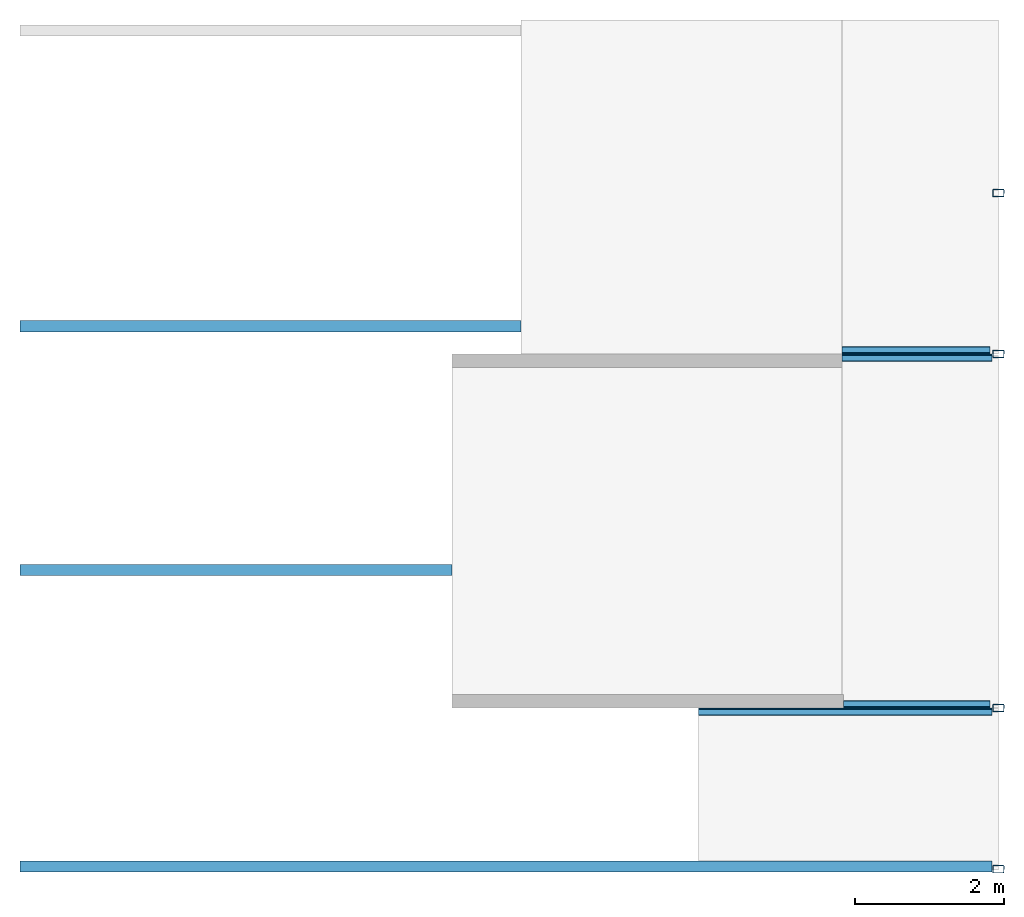
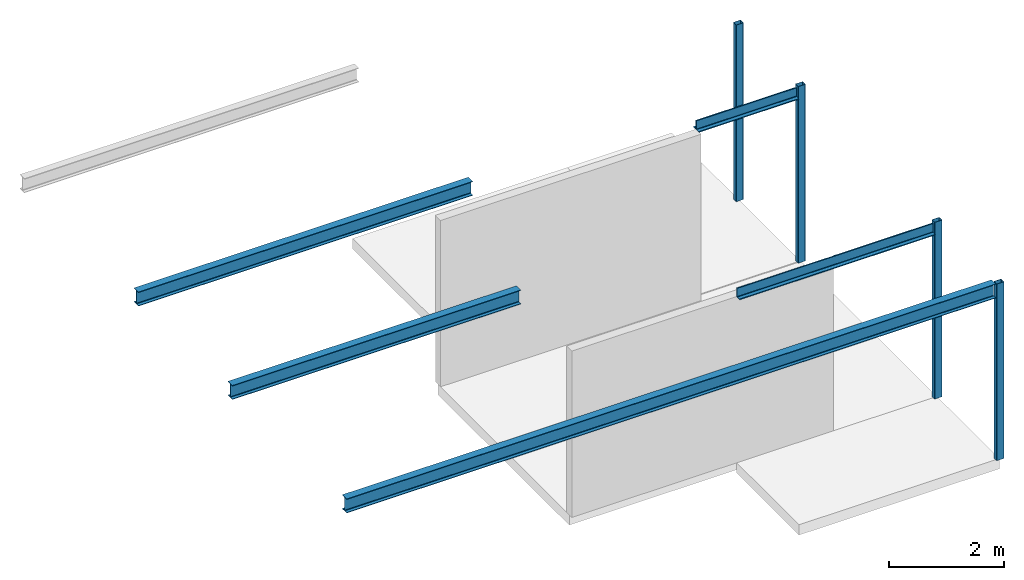
# One storey, part 1 of 2: 7 beams, 4 columns.
"""IFC2X3 building model written with IfcOpenShell, lengths in millimetres."""

from ifc_helpers import new_model, entity, si_unit, converted_unit, frame, frame_2d, origin, place, context, project, spatial, polyline, circle_curve, parameter, trimmed, segment, composite_curve, outline, extrude, source, transform, mapped, material, type_object, type_shapes, element, save


model = new_model("IFC2X3")

# Units and contexts
model_context = context("Model", 3, precision=1e-06, world=origin())
plan_context = context("Plan", 3, precision=1e-06, world=origin())
ifc_project = project(units=[si_unit("LENGTHUNIT", "METRE", prefix="MILLI"), si_unit("AREAUNIT", "SQUARE_METRE", prefix="MILLI"), si_unit("VOLUMEUNIT", "CUBIC_METRE", prefix="MILLI"), converted_unit("PLANEANGLEUNIT", "DEGREE", entity("IfcRatioMeasure", 0.01745329251994328), si_unit("PLANEANGLEUNIT", "RADIAN"), dimensions=[0, 0, 0, 0, 0, 0, 0]), si_unit("TIMEUNIT", "SECOND")], contexts=[model_context, plan_context])

# Site, building, storey
site_placement = place(None, origin())
site = spatial("IfcSite", under=ifc_project, at=site_placement, CompositionType="ELEMENT")
building_placement = place(None, origin())
building = spatial("IfcBuilding", under=site, at=building_placement, CompositionType="ELEMENT")
storey_placement = place(building_placement, frame((0.0, 0.0, 7500.0)))
storey = spatial("IfcBuildingStorey", under=building, at=storey_placement, Name="Level 3", CompositionType="ELEMENT", Elevation=7500.000000000001)

# Columns
ifc_material = material(Name="Metal - Steel - 345 MPa")
column_type = type_object("IfcColumnType", Name="150x100x5", PredefinedType="COLUMN")
shared_shape = source(origin(), model_context, "Body", "SweptSolid", [
    extrude(outline(composite_curve([segment(polyline([(-40.0, -75.0), (40.0, -75.0)]), True, "CONTINUOUS"), segment(trimmed(circle_curve(frame_2d((40.0, -65.0), x_axis=(-1.0, 0.0)), 9.999999999997998), [parameter(90.00000000000009)], [parameter(180.0000000000002)], True, "PARAMETER"), True, "CONTINUOUS"), segment(polyline([(50.0, -65.0), (50.0, 65.0)]), True, "CONTINUOUS"), segment(trimmed(circle_curve(frame_2d((40.0, 65.0), x_axis=(-1.0, 0.0)), 9.99999999999999), [parameter(179.9999999999999)], [parameter(269.9999999999997)], True, "PARAMETER"), True, "CONTINUOUS"), segment(polyline([(40.0, 75.0), (-40.0, 75.0)]), True, "CONTINUOUS"), segment(trimmed(circle_curve(frame_2d((-40.0, 65.0), x_axis=(-1.0, 0.0)), 10.00000000000288), [parameter(269.9999999999995)], [parameter(359.9999999999996)], True, "PARAMETER"), True, "CONTINUOUS"), segment(polyline([(-50.0, 65.0), (-50.0, -65.0)]), True, "CONTINUOUS"), segment(trimmed(circle_curve(frame_2d((-40.0, -65.0), x_axis=(-1.0, 0.0)), 9.999999999996726), [parameter(359.9999999999996)], [parameter(89.99999999999963)], True, "PARAMETER"), True, "CONTINUOUS")], self_intersect=False), holes=[composite_curve([segment(trimmed(circle_curve(frame_2d((-40.0, -65.0), x_axis=(-1.0, 0.0)), 4.999999999996471), [parameter(0.0)], [parameter(89.99999999999999)], True, "PARAMETER"), False, "CONTINUOUS"), segment(polyline([(-45.0, -65.0), (-45.0, 65.0)]), True, "CONTINUOUS"), segment(trimmed(circle_curve(frame_2d((-40.0, 65.0), x_axis=(-1.0, 0.0)), 4.999999999998176), [parameter(270.0)], [parameter(359.9999999999999)], True, "PARAMETER"), False, "CONTINUOUS"), segment(polyline([(-40.0, 70.0), (40.0, 70.0)]), True, "CONTINUOUS"), segment(trimmed(circle_curve(frame_2d((40.0, 65.0), x_axis=(-1.0, 0.0)), 5.000000000001551), [parameter(180.0000000000001)], [parameter(270.0)], True, "PARAMETER"), False, "CONTINUOUS"), segment(polyline([(45.0, 65.0), (45.0, -65.0)]), True, "CONTINUOUS"), segment(trimmed(circle_curve(frame_2d((40.0, -65.0), x_axis=(-1.0, 0.0)), 5.000000000000011), [parameter(90.0000000000005)], [parameter(179.9999999999998)], True, "PARAMETER"), False, "CONTINUOUS"), segment(polyline([(40.0, -70.0), (-40.0, -70.0)]), True, "CONTINUOUS")], self_intersect=False)]), frame((0.0, 0.0, 7500.0), z_axis=(0.0, 0.0, 1.0), x_axis=(-1.0, 0.0, 0.0)), (0.0, 0.0, 1.0), 3750.0),
])
type_shapes(column_type, [shared_shape])
for number, where, z_axis, x_axis in (
    (1, (-11917.18323242557, 151.098768151623, -7500.0), (0.0, 0.0, 1.0), (0.0, 1.0, 0.0)),
    (2, (-11917.18323242557, 2311.098768151621, -7500.0), (0.0, 0.0, 1.0), (0.0, 1.0, 0.0)),
    (3, (-11917.18323242557, 7061.098768151644, -7500.0), (0.0, 0.0, 1.0), (0.0, 1.0, 0.0)),
    (4, (-11917.18323242557, 9217.072263559809, -7500.0), (0.0, 0.0, 1.0), (0.0, 1.0, 0.0)),
):
    element("IfcColumn", number, at=place(storey_placement, frame(where, z_axis=z_axis, x_axis=x_axis)), inside=storey, type_object=column_type, material=ifc_material, ObjectType="150x100x5", context=model_context, shape_type="MappedRepresentation", body=[
        mapped(shared_shape, transform((0.0, 0.0, 0.0), scale=1.0)),
    ])

# Beams
beam_1_placement = place(storey_placement, frame((-12017.18323242538, 7061.098768151644, 3750.0), z_axis=(0.0, 0.0, 1.0), x_axis=(0.0, 1.0, 0.0)))
element("IfcBeam", 5, at=beam_1_placement, inside=storey, material=ifc_material, ObjectType="L-Angles:CAI200x100x14", context=model_context, shape_type="SweptSolid", body=[
    extrude(outline(composite_curve([segment(polyline([(-34.57142857142937, -63.1428571428558), (65.42857142857281, -63.1428571428558)]), True, "CONTINUOUS"), segment(trimmed(circle_curve(frame_2d((51.42857142857381, -63.1428571428558), x_axis=(1.0, 0.0)), 14.0), [parameter(1.017777498068326e-13)], [parameter(90.00000000000009)], True, "PARAMETER"), True, "CONTINUOUS"), segment(polyline([(51.42857142857381, -49.1428571428568), (-6.571428571429244, -49.1428571428568)]), True, "CONTINUOUS"), segment(trimmed(circle_curve(frame_2d((-6.571428571428161, -35.14285714285566), x_axis=(1.0, 0.0)), 14.0), [parameter(180.0000000000001)], [parameter(269.9999999999999)], True, "PARAMETER"), False, "CONTINUOUS"), segment(polyline([(-20.57142857142823, -35.14285714285566), (-20.57142857142823, 122.8571428571452)]), True, "CONTINUOUS"), segment(trimmed(circle_curve(frame_2d((-34.57142857142829, 122.8571428571431), x_axis=(1.0, 0.0)), 14.0), [parameter(0.0)], [parameter(90.00000000000024)], True, "PARAMETER"), True, "CONTINUOUS"), segment(polyline([(-34.57142857142829, 136.8571428571442), (-34.57142857142937, -63.1428571428558)]), True, "CONTINUOUS")], self_intersect=False)), frame((34.57142857142829, 1994.442034597584, -170.8571428571387), z_axis=(0.0, -1.0, 0.0), x_axis=(1.0, 0.0, 0.0)), (0.0, 0.0, 1.0), 1981.742033987986),
])
beam_2_placement = place(storey_placement, frame((-14011.62526702297, 7061.098768151647, 3750.0), z_axis=(0.0, 0.0, 1.0), x_axis=(0.0, -1.0, 0.0)))
element("IfcBeam", 6, at=beam_2_placement, inside=storey, material=ifc_material, ObjectType="L-Angles:CAI200x100x14", context=model_context, shape_type="SweptSolid", body=[
    extrude(outline(composite_curve([segment(polyline([(-63.14285714285599, -34.57142857142903), (136.857142857144, -34.57142857142903)]), True, "CONTINUOUS"), segment(trimmed(circle_curve(frame_2d((122.8571428571429, -34.57142857142896), x_axis=(0.0, 1.0)), 14.0), [parameter(269.9999999999998)], [parameter(0.0)], True, "PARAMETER"), True, "CONTINUOUS"), segment(polyline([(122.8571428571451, -20.57142857142889), (-35.14285714285578, -20.57142857142804)]), True, "CONTINUOUS"), segment(trimmed(circle_curve(frame_2d((-35.1428571428557, -6.571428571427971), x_axis=(0.0, 1.0)), 14.0), [parameter(90.00000000000009)], [parameter(179.9999999999999)], True, "PARAMETER"), False, "CONTINUOUS"), segment(polyline([(-49.14285714285683, -6.571428571428978), (-49.14285714285652, 51.42857142857407)]), True, "CONTINUOUS"), segment(trimmed(circle_curve(frame_2d((-63.14285714285553, 51.42857142857415), x_axis=(0.0, 1.0)), 14.0), [parameter(269.9999999999999)], [parameter(359.9999999999999)], True, "PARAMETER"), True, "CONTINUOUS"), segment(polyline([(-63.14285714285545, 65.42857142857315), (-63.14285714285599, -34.57142857142903)]), True, "CONTINUOUS")], self_intersect=False)), frame((34.57142857142829, 0.0, -170.8571428571387), z_axis=(0.0, 1.0, 0.0), x_axis=(0.0, 0.0, 1.0)), (0.0, 0.0, 1.0), 2006.742034597402),
])
beam_3_placement = place(storey_placement, frame((-12017.18323242539, 2311.098768151621, 3750.0), z_axis=(0.0, 0.0, 1.0), x_axis=(0.0, 1.0, 0.0)))
element("IfcBeam", 7, at=beam_3_placement, inside=storey, material=ifc_material, ObjectType="L-Angles:CAI200x100x14", context=model_context, shape_type="SweptSolid", body=[
    extrude(outline(composite_curve([segment(polyline([(-34.5714285714291, -63.1428571428558), (65.42857142857306, -63.1428571428558)]), True, "CONTINUOUS"), segment(trimmed(circle_curve(frame_2d((51.428571428573, -63.1428571428558), x_axis=(0.0, 1.0)), 14.0), [parameter(269.9999999999999)], [parameter(359.9999999999999)], True, "PARAMETER"), True, "CONTINUOUS"), segment(polyline([(51.428571428573, -49.1428571428568), (-6.571428571428971, -49.1428571428568)]), True, "CONTINUOUS"), segment(trimmed(circle_curve(frame_2d((-6.571428571428971, -35.14285714285566), x_axis=(-1.0, 0.0)), 14.0), [parameter(3.562221243239142e-13)], [parameter(90.00000000000009)], True, "PARAMETER"), False, "CONTINUOUS"), segment(polyline([(-20.57142857142904, -35.14285714285566), (-20.5714285714285, 122.8571428571452)]), True, "CONTINUOUS"), segment(trimmed(circle_curve(frame_2d((-34.57142857142856, 122.8571428571431), x_axis=(0.0, 1.0)), 14.0), [parameter(269.9999999999999)], [parameter(1.52666624710249e-13)], True, "PARAMETER"), True, "CONTINUOUS"), segment(polyline([(-34.57142857142856, 136.8571428571442), (-34.5714285714291, -63.1428571428558)]), True, "CONTINUOUS")], self_intersect=False)), frame((34.57142857142883, 1980.0, -170.8571428571387), z_axis=(0.0, -1.0, 0.0), x_axis=(1.0, 0.0, 0.0)), (0.0, 0.0, 1.0), 1967.299999390401),
])
beam_4_placement = place(storey_placement, frame((-14011.62526702298, 2311.098768151623, 3750.0), z_axis=(0.0, 0.0, 1.0), x_axis=(0.0, -1.0, 0.0)))
element("IfcBeam", 8, at=beam_4_placement, inside=storey, material=ifc_material, ObjectType="L-Angles:CAI200x100x14", context=model_context, shape_type="SweptSolid", body=[
    extrude(outline(composite_curve([segment(polyline([(-63.1428571428559, -34.57142857142947), (136.8571428571441, -34.57142857142947)]), True, "CONTINUOUS"), segment(trimmed(circle_curve(frame_2d((122.857142857143, -34.57142857142944), x_axis=(1.0, 0.0)), 14.0), [parameter(359.9999999999998)], [parameter(90.00000000000009)], True, "PARAMETER"), True, "CONTINUOUS"), segment(polyline([(122.8571428571452, -20.57142857142937), (-35.14285714285572, -20.57142857142948)]), True, "CONTINUOUS"), segment(trimmed(circle_curve(frame_2d((-35.14285714285568, -6.571428571429416), x_axis=(0.0, -1.0)), 14.0), [parameter(269.9999999999999)], [parameter(359.9999999999997)], True, "PARAMETER"), False, "CONTINUOUS"), segment(polyline([(-49.14285714285682, -6.571428571429378), (-49.14285714285666, 51.4285714285726)]), True, "CONTINUOUS"), segment(trimmed(circle_curve(frame_2d((-63.14285714285566, 51.42857142857263), x_axis=(1.0, 0.0)), 14.0), [parameter(1.017777498068326e-13)], [parameter(90.00000000000009)], True, "PARAMETER"), True, "CONTINUOUS"), segment(polyline([(-63.14285714285563, 65.4285714285727), (-63.1428571428559, -34.57142857142947)]), True, "CONTINUOUS")], self_intersect=False)), frame((34.5714285714291, -1925.557965402417, -170.8571428571387), z_axis=(0.0, 1.0, 0.0), x_axis=(0.0, 0.0, 1.0)), (0.0, 0.0, 1.0), 3932.299999999817),
])
beam_5_placement = place(storey_placement, frame((-25047.1840102249, 7431.347281587448, 3750.0), z_axis=(0.0, 0.0, 1.0), x_axis=(0.0, -1.0, 0.0)))
element("IfcBeam", 9, at=beam_5_placement, inside=storey, material=ifc_material, Name="IPE-Beams:IPE300:IPE300", ObjectType="IPE-Beams:IPE300", context=model_context, shape_type="SweptSolid", body=[
    extrude(outline(composite_curve([segment(polyline([(-75.0, -139.3000000000008), (-75.0, -150.0)]), True, "CONTINUOUS"), segment(polyline([(-75.0, -150.0), (75.0, -150.0)]), True, "CONTINUOUS"), segment(polyline([(75.0, -150.0), (75.0, -139.3000000000008)]), True, "CONTINUOUS"), segment(polyline([(75.0, -139.3000000000008), (18.55000000000011, -139.3000000000008)]), True, "CONTINUOUS"), segment(trimmed(circle_curve(frame_2d((18.55000000000011, -124.2999999999999), x_axis=(1.0, 0.0)), 15.0), [parameter(180.0)], [parameter(269.9999999999996)], True, "PARAMETER"), False, "CONTINUOUS"), segment(polyline([(3.550000000000276, -124.2999999999999), (3.550000000000276, 124.2999999999999)]), True, "CONTINUOUS"), segment(trimmed(circle_curve(frame_2d((18.55000000000011, 124.2999999999999), x_axis=(1.0, 0.0)), 15.0), [parameter(90.00000000000009)], [parameter(180.0000000000002)], True, "PARAMETER"), False, "CONTINUOUS"), segment(polyline([(18.55000000000011, 139.2999999999987), (75.0, 139.2999999999987)]), True, "CONTINUOUS"), segment(polyline([(75.0, 139.2999999999987), (75.0, 150.0)]), True, "CONTINUOUS"), segment(polyline([(75.0, 150.0), (-75.0, 150.0)]), True, "CONTINUOUS"), segment(polyline([(-75.0, 150.0), (-75.0, 139.2999999999987)]), True, "CONTINUOUS"), segment(polyline([(-75.0, 139.2999999999987), (-18.54999999999903, 139.2999999999987)]), True, "CONTINUOUS"), segment(trimmed(circle_curve(frame_2d((-18.55000000000011, 124.2999999999999), x_axis=(1.0, 0.0)), 15.0), [parameter(359.9999999999996)], [parameter(89.99999999999973)], True, "PARAMETER"), False, "CONTINUOUS"), segment(polyline([(-3.549999999999193, 124.2999999999999), (-3.549999999999193, -124.2999999999999)]), True, "CONTINUOUS"), segment(trimmed(circle_curve(frame_2d((-18.55000000000011, -124.2999999999999), x_axis=(1.0, 0.0)), 15.0), [parameter(269.9999999999999)], [parameter(0.0)], True, "PARAMETER"), False, "CONTINUOUS"), segment(polyline([(-18.54999999999903, -139.3000000000008), (-75.0, -139.3000000000008)]), True, "CONTINUOUS")], self_intersect=False)), frame((0.0, 10.00077779953173, -150.0), z_axis=(0.0, -1.0, 0.0), x_axis=(1.0, 0.0, 0.0)), (0.0, 0.0, -1.0), 6714.999999999998),
])
beam_6_placement = place(storey_placement, frame((-25037.18323242538, 4161.098768151625, 3750.0), z_axis=(0.0, 0.0, 1.0), x_axis=(0.0, -1.0, 0.0)))
element("IfcBeam", 10, at=beam_6_placement, inside=storey, material=ifc_material, Name="IPE-Beams:IPE300:IPE300", ObjectType="IPE-Beams:IPE300", context=model_context, shape_type="SweptSolid", body=[
    extrude(outline(composite_curve([segment(polyline([(-75.0, -139.3000000000008), (-75.0, -150.0)]), True, "CONTINUOUS"), segment(polyline([(-75.0, -150.0), (75.0, -150.0)]), True, "CONTINUOUS"), segment(polyline([(75.0, -150.0), (75.0, -139.3000000000008)]), True, "CONTINUOUS"), segment(polyline([(75.0, -139.3000000000008), (18.55000000000065, -139.3000000000008)]), True, "CONTINUOUS"), segment(trimmed(circle_curve(frame_2d((18.5500000000012, -124.2999999999999), x_axis=(0.0, -1.0)), 15.0), [parameter(269.9999999999999)], [parameter(359.9999999999995)], True, "PARAMETER"), False, "CONTINUOUS"), segment(polyline([(3.550000000000817, -124.2999999999999), (3.550000000000817, 124.2999999999999)]), True, "CONTINUOUS"), segment(trimmed(circle_curve(frame_2d((18.5500000000012, 124.2999999999999), x_axis=(-1.0, 0.0)), 15.0), [parameter(269.9999999999999)], [parameter(0.0)], True, "PARAMETER"), False, "CONTINUOUS"), segment(polyline([(18.55000000000065, 139.2999999999987), (75.0, 139.2999999999987)]), True, "CONTINUOUS"), segment(polyline([(75.0, 139.2999999999987), (75.0, 150.0)]), True, "CONTINUOUS"), segment(polyline([(75.0, 150.0), (-75.0, 150.0)]), True, "CONTINUOUS"), segment(polyline([(-75.0, 150.0), (-75.0, 139.2999999999987)]), True, "CONTINUOUS"), segment(polyline([(-75.0, 139.2999999999987), (-18.54999999999957, 139.2999999999987)]), True, "CONTINUOUS"), segment(trimmed(circle_curve(frame_2d((-18.54999999999849, 124.2999999999999), x_axis=(0.0, 1.0)), 15.0), [parameter(269.9999999999999)], [parameter(1.017777498068326e-13)], True, "PARAMETER"), False, "CONTINUOUS"), segment(polyline([(-3.549999999999734, 124.2999999999999), (-3.549999999999734, -124.2999999999999)]), True, "CONTINUOUS"), segment(trimmed(circle_curve(frame_2d((-18.54999999999849, -124.2999999999999), x_axis=(1.0, 0.0)), 15.0), [parameter(269.9999999999999)], [parameter(0.0)], True, "PARAMETER"), False, "CONTINUOUS"), segment(polyline([(-18.54999999999957, -139.3000000000008), (-75.0, -139.3000000000008)]), True, "CONTINUOUS")], self_intersect=False)), frame((0.0, 0.0, -150.0), z_axis=(0.0, -1.0, 0.0), x_axis=(1.0, 0.0, 0.0)), (0.0, 0.0, -1.0), 5789.999222200484),
])
beam_7_placement = place(storey_placement, frame((-25047.1840102249, 189.0987681516164, 3750.0), z_axis=(0.0, 0.0, 1.0), x_axis=(0.0, -1.0, 0.0)))
element("IfcBeam", 11, at=beam_7_placement, inside=storey, material=ifc_material, Name="IPE-Beams:IPE300:IPE300", ObjectType="IPE-Beams:IPE300", context=model_context, shape_type="SweptSolid", body=[
    extrude(outline(composite_curve([segment(polyline([(-75.0, -139.3000000000008), (-75.0, -150.0)]), True, "CONTINUOUS"), segment(polyline([(-75.0, -150.0), (75.0, -150.0)]), True, "CONTINUOUS"), segment(polyline([(75.0, -150.0), (75.0, -139.3000000000008)]), True, "CONTINUOUS"), segment(polyline([(75.0, -139.3000000000008), (18.54999999999998, -139.3000000000008)]), True, "CONTINUOUS"), segment(trimmed(circle_curve(frame_2d((18.54999999999998, -124.2999999999999), x_axis=(1.0, 0.0)), 15.0), [parameter(180.0)], [parameter(269.9999999999996)], True, "PARAMETER"), False, "CONTINUOUS"), segment(polyline([(3.549999999999938, -124.2999999999999), (3.549999999999938, 124.2999999999999)]), True, "CONTINUOUS"), segment(trimmed(circle_curve(frame_2d((18.54999999999998, 124.2999999999999), x_axis=(1.0, 0.0)), 15.0), [parameter(90.00000000000009)], [parameter(180.0000000000002)], True, "PARAMETER"), False, "CONTINUOUS"), segment(polyline([(18.54999999999998, 139.2999999999987), (75.0, 139.2999999999987)]), True, "CONTINUOUS"), segment(polyline([(75.0, 139.2999999999987), (75.0, 150.0)]), True, "CONTINUOUS"), segment(polyline([(75.0, 150.0), (-75.0, 150.0)]), True, "CONTINUOUS"), segment(polyline([(-75.0, 150.0), (-75.0, 139.2999999999987)]), True, "CONTINUOUS"), segment(polyline([(-75.0, 139.2999999999987), (-18.55000000000011, 139.2999999999987)]), True, "CONTINUOUS"), segment(trimmed(circle_curve(frame_2d((-18.55000000000011, 124.2999999999999), x_axis=(1.0, 0.0)), 15.0), [parameter(359.9999999999996)], [parameter(89.99999999999973)], True, "PARAMETER"), False, "CONTINUOUS"), segment(polyline([(-3.55000000000014, 124.2999999999999), (-3.55000000000014, -124.2999999999999)]), True, "CONTINUOUS"), segment(trimmed(circle_curve(frame_2d((-18.55000000000011, -124.2999999999999), x_axis=(1.0, 0.0)), 15.0), [parameter(269.9999999999999)], [parameter(0.0)], True, "PARAMETER"), False, "CONTINUOUS"), segment(polyline([(-18.55000000000011, -139.3000000000008), (-75.0, -139.3000000000008)]), True, "CONTINUOUS")], self_intersect=False)), frame((0.0, 10.0, -150.0), z_axis=(0.0, -1.0, 0.0), x_axis=(1.0, 0.0, 0.0)), (0.0, 0.0, -1.0), 13032.30077779933),
])

save(model, "model.ifc")
